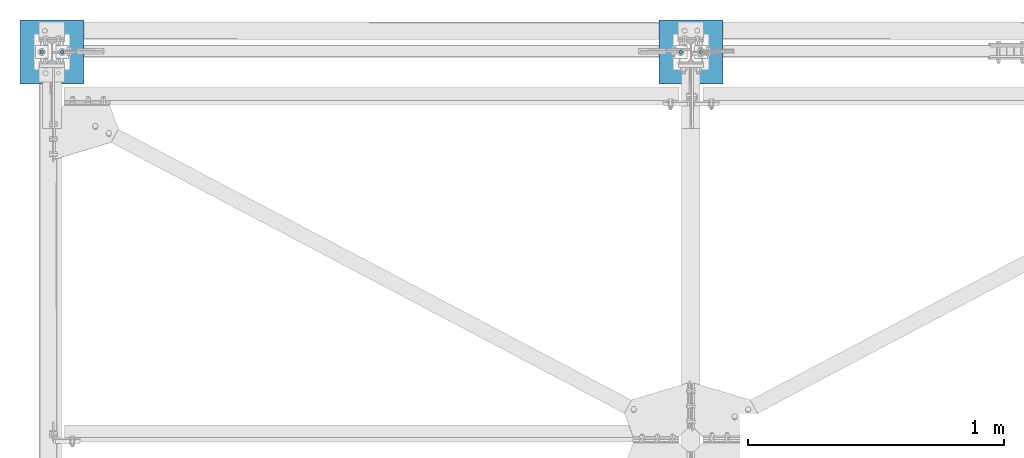
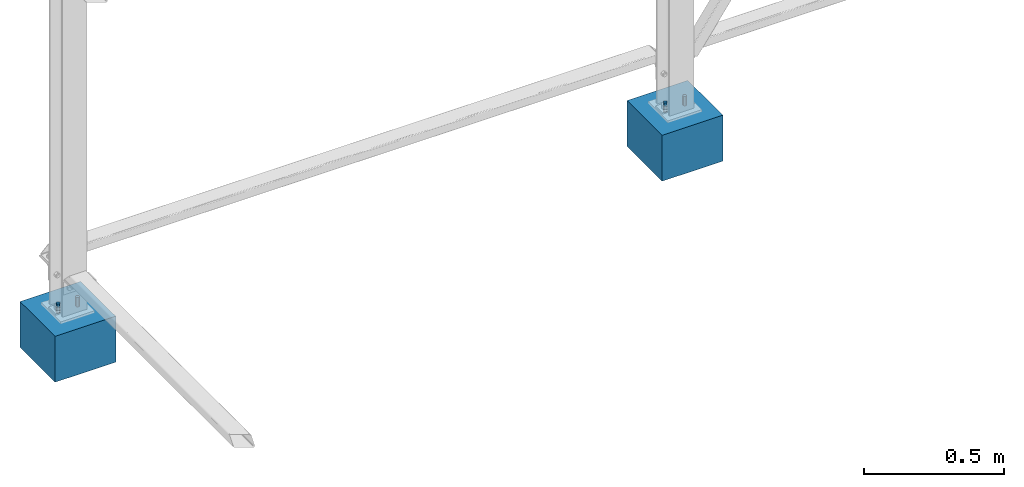
# One storey, part 3 of 28: 6 columns, 6 elements without a shape of their own.
"""IFC2X3 building model written with IfcOpenShell, lengths in millimetres."""

from ifc_helpers import new_model, si_unit, frame, origin_with_axes, origin_2d_with_axis, place, context, subcontext, project, spatial, rectangle, circle, extrude, material, type_object, element, aggregate, save


model = new_model("IFC2X3")

# Units and contexts
model_context = context("Model", 3, precision=1e-05, world=origin_with_axes())
body_context = subcontext(model_context, "Body", "Model", "MODEL_VIEW")
ifc_project = project(units=[si_unit("LENGTHUNIT", "METRE", prefix="MILLI"), si_unit("AREAUNIT", "SQUARE_METRE"), si_unit("VOLUMEUNIT", "CUBIC_METRE"), si_unit("MASSUNIT", "GRAM", prefix="KILO"), si_unit("TIMEUNIT", "SECOND"), si_unit("PLANEANGLEUNIT", "RADIAN"), si_unit("SOLIDANGLEUNIT", "STERADIAN"), si_unit("THERMODYNAMICTEMPERATUREUNIT", "DEGREE_CELSIUS"), si_unit("LUMINOUSINTENSITYUNIT", "LUMEN")], contexts=[model_context])

# Site, building, storey
site_placement = place(None, origin_with_axes())
site = spatial("IfcSite", under=ifc_project, at=site_placement, CompositionType="ELEMENT")
building_placement = place(site_placement, origin_with_axes())
building = spatial("IfcBuilding", under=site, at=building_placement, Name="Undefined", CompositionType="ELEMENT")
storey_placement = place(building_placement, origin_with_axes())
storey = spatial("IfcBuildingStorey", under=building, at=storey_placement, Name="Undefined", CompositionType="ELEMENT", Elevation=0.0)

# Assembly, column
assembly_1_placement = place(storey_placement, origin_with_axes())
assembly_1 = element("IfcElementAssembly", 1, at=assembly_1_placement, inside=storey, AssemblyPlace="NOTDEFINED", PredefinedType="NOTDEFINED")
ifc_material_1 = material(Name="STEEL/S235JR")
column_type_1 = type_object("IfcColumnType", Name="D14", PredefinedType="NOTDEFINED")
column_1_placement = place(assembly_1_placement, frame((2459.99999999999, 3000.00000000096, 239.999895901093), z_axis=(0.0, 0.0, -1.0), x_axis=(0.0, -1.0, 0.0)))
column_1 = element("IfcColumn", 2, at=column_1_placement, type_object=column_type_1, material=ifc_material_1, context=body_context, shape_type="SweptSolid", body=[
    extrude(circle(Radius=7.0, at=origin_2d_with_axis()), frame((0.0, 0.0, 200.0), z_axis=(0.0, 0.0, -1.0), x_axis=(0.0, 1.0, 0.0)), (0.0, 0.0, 1.0), 200.0),
])
aggregate(assembly_1, [column_1])

assembly_2_placement = place(storey_placement, origin_with_axes())
assembly_2 = element("IfcElementAssembly", 3, at=assembly_2_placement, inside=storey, AssemblyPlace="NOTDEFINED", PredefinedType="NOTDEFINED")
column_2_placement = place(assembly_2_placement, frame((2539.99999999999, 3000.00000000096, 239.999895901093), z_axis=(0.0, 0.0, -1.0), x_axis=(0.0, 1.0, 0.0)))
column_2 = element("IfcColumn", 4, at=column_2_placement, type_object=column_type_1, material=ifc_material_1, context=body_context, shape_type="SweptSolid", body=[
    extrude(circle(Radius=7.0, at=origin_2d_with_axis()), frame((0.0, 0.0, 200.0), z_axis=(0.0, 0.0, -1.0), x_axis=(0.0, 1.0, 0.0)), (0.0, 0.0, 1.0), 200.0),
])
aggregate(assembly_2, [column_2])

assembly_3_placement = place(storey_placement, origin_with_axes())
assembly_3 = element("IfcElementAssembly", 5, at=assembly_3_placement, inside=storey, AssemblyPlace="NOTDEFINED", PredefinedType="NOTDEFINED")
column_3_placement = place(assembly_3_placement, frame((-40.000000000382, 3000.00000000099, 239.999895901093), z_axis=(0.0, 0.0, -1.0), x_axis=(0.0, -1.0, 0.0)))
column_3 = element("IfcColumn", 6, at=column_3_placement, type_object=column_type_1, material=ifc_material_1, context=body_context, shape_type="SweptSolid", body=[
    extrude(circle(Radius=7.0, at=origin_2d_with_axis()), frame((0.0, 0.0, 200.0), z_axis=(0.0, 0.0, -1.0), x_axis=(0.0, 1.0, 0.0)), (0.0, 0.0, 1.0), 200.0),
])
aggregate(assembly_3, [column_3])

assembly_4_placement = place(storey_placement, origin_with_axes())
assembly_4 = element("IfcElementAssembly", 7, at=assembly_4_placement, inside=storey, AssemblyPlace="NOTDEFINED", PredefinedType="NOTDEFINED")
column_4_placement = place(assembly_4_placement, frame((39.9999999996179, 3000.00000000099, 239.999895901093), z_axis=(0.0, 0.0, -1.0), x_axis=(0.0, 1.0, 0.0)))
column_4 = element("IfcColumn", 8, at=column_4_placement, type_object=column_type_1, material=ifc_material_1, context=body_context, shape_type="SweptSolid", body=[
    extrude(circle(Radius=7.0, at=origin_2d_with_axis()), frame((0.0, 0.0, 200.0), z_axis=(0.0, 0.0, -1.0), x_axis=(0.0, 1.0, 0.0)), (0.0, 0.0, 1.0), 200.0),
])
aggregate(assembly_4, [column_4])

assembly_5_placement = place(storey_placement, origin_with_axes())
assembly_5 = element("IfcElementAssembly", 9, at=assembly_5_placement, inside=storey, Name="POTEAU", AssemblyPlace="NOTDEFINED", PredefinedType="NOTDEFINED")
ifc_material_2 = material(Name="CONCRETE/C25/30")
column_type_2 = type_object("IfcColumnType", PredefinedType="NOTDEFINED")
column_5_placement = place(assembly_5_placement, frame((2500.0, 3000.0, 0.0), z_axis=(0.0, 0.0, 1.0), x_axis=(0.0, 1.0, 0.0)))
column_5 = element("IfcColumn", 10, at=column_5_placement, type_object=column_type_2, material=ifc_material_2, Name="POTEAU", context=body_context, shape_type="SweptSolid", body=[
    extrude(rectangle(XDim=250.0, YDim=250.0, at=origin_2d_with_axis()), frame((0.0, 0.0, 200.0), z_axis=(0.0, 0.0, -1.0), x_axis=(0.0, 1.0, 0.0)), (0.0, 0.0, 1.0), 200.0),
])
aggregate(assembly_5, [column_5])

assembly_6_placement = place(storey_placement, origin_with_axes())
assembly_6 = element("IfcElementAssembly", 11, at=assembly_6_placement, inside=storey, Name="POTEAU", AssemblyPlace="NOTDEFINED", PredefinedType="NOTDEFINED")
column_6_placement = place(assembly_6_placement, frame((0.0, 3000.0, 0.0), z_axis=(0.0, 0.0, 1.0), x_axis=(0.0, 1.0, 0.0)))
column_6 = element("IfcColumn", 12, at=column_6_placement, type_object=column_type_2, material=ifc_material_2, Name="POTEAU", context=body_context, shape_type="SweptSolid", body=[
    extrude(rectangle(XDim=250.0, YDim=250.0, at=origin_2d_with_axis()), frame((0.0, 0.0, 200.0), z_axis=(0.0, 0.0, -1.0), x_axis=(0.0, 1.0, 0.0)), (0.0, 0.0, 1.0), 200.0),
])
aggregate(assembly_6, [column_6])

save(model, "model.ifc")
